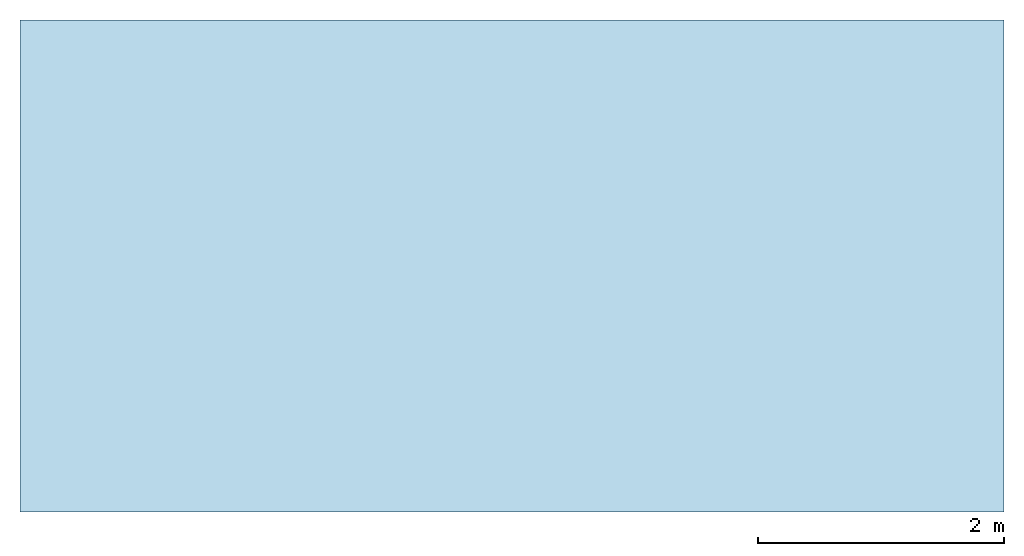
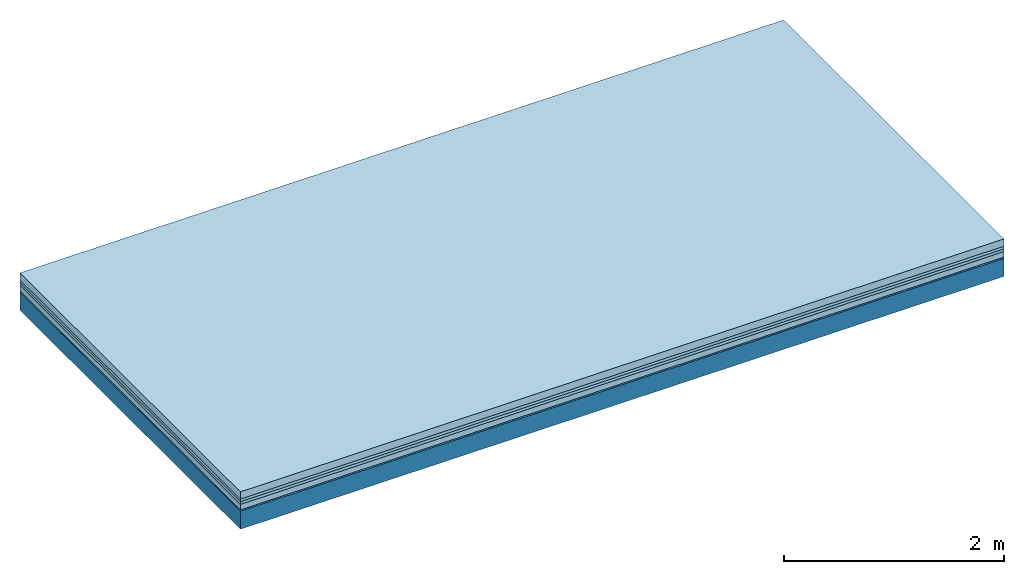
# One storey: 5 plates, 1 member, 1 element without a shape of its own.
"""IFC4 building model written with IfcOpenShell, lengths in metres."""

from ifc_helpers import new_model, si_unit, derived_unit, direction, frame, frame_2d, origin, origin_with_axes, place, context, project, spatial, rectangle, extrude, material, layer, layer_set, type_object, element, aggregate, save


model = new_model("IFC4")

# Units and contexts
plan_context = context("Plan", 3, precision=1e-05, world=origin(), true_north=direction((0.0, 1.0)))
model_context = context("Model", 3, precision=1e-05, world=origin(), true_north=direction((0.0, 1.0)))
ifc_project = project(units=[si_unit("LENGTHUNIT", "METRE"), derived_unit("SOUNDPRESSUREUNIT", [(si_unit("PRESSUREUNIT", "PASCAL", prefix="MICRO"), 0)]), si_unit("ENERGYUNIT", "JOULE", prefix="MEGA"), si_unit("MASSUNIT", "GRAM", prefix="KILO"), derived_unit("THERMALTRANSMITTANCEUNIT", [(si_unit("POWERUNIT", "WATT"), 1), (si_unit("AREAUNIT", "SQUARE_METRE"), -1), (si_unit("THERMODYNAMICTEMPERATUREUNIT", "KELVIN"), -1)]), derived_unit("AREADENSITYUNIT", [(si_unit("MASSUNIT", "GRAM", prefix="KILO"), 1), (si_unit("AREAUNIT", "SQUARE_METRE"), -1)]), derived_unit("USERDEFINED", [(si_unit("ENERGYUNIT", "JOULE", prefix="MEGA"), 1), (si_unit("AREAUNIT", "SQUARE_METRE"), -1)])], contexts=[plan_context, model_context])

# Site, building, storey
site = spatial("IfcSite", under=ifc_project)
building_placement = place(None, origin())
building = spatial("IfcBuilding", under=site, at=building_placement)
storey_placement = place(building_placement, origin())
storey = spatial("IfcBuildingStorey", under=building, at=storey_placement)

# Slab, member, plates
ifc_material_1 = material(Name="Cement screed", Category="04.006")
ifc_layer_1 = layer(ifc_material_1, 0.08, Name="On-material")
ifc_material_2 = material()
ifc_layer_2 = layer(ifc_material_2, 0.03, Name="Impact sound insulation")
ifc_material_3 = material()
ifc_layer_3 = layer(ifc_material_3, 0.03, Name="Additional insulation")
ifc_material_4 = material(Category="03.011")
ifc_layer_4 = layer(ifc_material_4, 0.06, Name="on Supporting structure")
ifc_material_5 = material(Category="03.007")
ifc_layer_5 = layer(ifc_material_5, 0.015, Name="Sub-floor")
ifc_material_6 = material(Name="of the art")
ifc_layer_6 = layer(ifc_material_6, 0.0, Name="Bond")
ifc_layer_7 = layer(None, 0.2, Name="Supporting structure")
ifc_layer_set = layer_set([ifc_layer_1, ifc_layer_2, ifc_layer_3, ifc_layer_4, ifc_layer_5, ifc_layer_6, ifc_layer_7])
slab_type = type_object("IfcSlabType", Name="A1092", PredefinedType="NOTDEFINED", material=ifc_layer_set)
slab_placement = place(None, frame((0.0, 0.0, 0.0), z_axis=(0.0, 0.0, -1.0), x_axis=(1.0, 0.0, 0.0)))
slab = element("IfcSlab", 1, at=slab_placement, inside=storey, type_object=slab_type, material=ifc_layer_set, Name="Slab #1")
ifc_material_7 = material()
member_placement = place(slab_placement, origin())
member = element("IfcMember", 2, at=member_placement, material=ifc_material_7, Name="Supporting structure", context=plan_context, shape_type="SweptSolid", body=[
    extrude(rectangle(XDim=1.0, YDim=0.2, at=frame_2d((0.5, 0.1), x_axis=(1.0, 0.0))), frame((0.0, 4.0, 0.215), z_axis=(0.0, -1.0, 0.0), x_axis=(1.0, 0.0, 0.0)), (0.0, 0.0, 1.0), 4.0),
    extrude(rectangle(XDim=1.0, YDim=0.2, at=frame_2d((0.5, 0.1), x_axis=(1.0, 0.0))), frame((1.0, 4.0, 0.215), z_axis=(0.0, -1.0, 0.0), x_axis=(1.0, 0.0, 0.0)), (0.0, 0.0, 1.0), 4.0),
    extrude(rectangle(XDim=1.0, YDim=0.2, at=frame_2d((0.5, 0.1), x_axis=(1.0, 0.0))), frame((2.0, 4.0, 0.215), z_axis=(0.0, -1.0, 0.0), x_axis=(1.0, 0.0, 0.0)), (0.0, 0.0, 1.0), 4.0),
    extrude(rectangle(XDim=1.0, YDim=0.2, at=frame_2d((0.5, 0.1), x_axis=(1.0, 0.0))), frame((3.0, 4.0, 0.215), z_axis=(0.0, -1.0, 0.0), x_axis=(1.0, 0.0, 0.0)), (0.0, 0.0, 1.0), 4.0),
    extrude(rectangle(XDim=1.0, YDim=0.2, at=frame_2d((0.5, 0.1), x_axis=(1.0, 0.0))), frame((4.0, 4.0, 0.215), z_axis=(0.0, -1.0, 0.0), x_axis=(1.0, 0.0, 0.0)), (0.0, 0.0, 1.0), 4.0),
    extrude(rectangle(XDim=1.0, YDim=0.2, at=frame_2d((0.5, 0.1), x_axis=(1.0, 0.0))), frame((5.0, 4.0, 0.215), z_axis=(0.0, -1.0, 0.0), x_axis=(1.0, 0.0, 0.0)), (0.0, 0.0, 1.0), 4.0),
    extrude(rectangle(XDim=1.0, YDim=0.2, at=frame_2d((0.5, 0.1), x_axis=(1.0, 0.0))), frame((6.0, 4.0, 0.215), z_axis=(0.0, -1.0, 0.0), x_axis=(1.0, 0.0, 0.0)), (0.0, 0.0, 1.0), 4.0),
    extrude(rectangle(XDim=1.0, YDim=0.2, at=frame_2d((0.5, 0.1), x_axis=(1.0, 0.0))), frame((7.0, 4.0, 0.215), z_axis=(0.0, -1.0, 0.0), x_axis=(1.0, 0.0, 0.0)), (0.0, 0.0, 1.0), 4.0),
])
plate_1_placement = place(slab_placement, origin())
plate_1 = element("IfcPlate", 3, at=plate_1_placement, material=ifc_material_1, Name="On-material", context=plan_context, shape_type="SweptSolid", body=[
    extrude(rectangle(XDim=8.0, YDim=4.0, at=frame_2d((4.0, 2.0), x_axis=(1.0, 0.0))), origin_with_axes(), (0.0, 0.0, 1.0), 0.08),
])
plate_2_placement = place(slab_placement, origin())
plate_2 = element("IfcPlate", 4, at=plate_2_placement, material=ifc_material_2, Name="Impact sound insulation", context=plan_context, shape_type="SweptSolid", body=[
    extrude(rectangle(XDim=8.0, YDim=4.0, at=frame_2d((4.0, 2.0), x_axis=(1.0, 0.0))), frame((0.0, 0.0, 0.08), z_axis=(0.0, 0.0, 1.0), x_axis=(1.0, 0.0, 0.0)), (0.0, 0.0, 1.0), 0.03),
])
plate_3_placement = place(slab_placement, origin())
plate_3 = element("IfcPlate", 5, at=plate_3_placement, material=ifc_material_3, Name="Additional insulation", context=plan_context, shape_type="SweptSolid", body=[
    extrude(rectangle(XDim=8.0, YDim=4.0, at=frame_2d((4.0, 2.0), x_axis=(1.0, 0.0))), frame((0.0, 0.0, 0.11), z_axis=(0.0, 0.0, 1.0), x_axis=(1.0, 0.0, 0.0)), (0.0, 0.0, 1.0), 0.03),
])
plate_4_placement = place(slab_placement, origin())
plate_4 = element("IfcPlate", 6, at=plate_4_placement, material=ifc_material_4, Name="on Supporting structure", context=plan_context, shape_type="SweptSolid", body=[
    extrude(rectangle(XDim=8.0, YDim=4.0, at=frame_2d((4.0, 2.0), x_axis=(1.0, 0.0))), frame((0.0, 0.0, 0.14), z_axis=(0.0, 0.0, 1.0), x_axis=(1.0, 0.0, 0.0)), (0.0, 0.0, 1.0), 0.06),
])
plate_5_placement = place(slab_placement, origin())
plate_5 = element("IfcPlate", 7, at=plate_5_placement, material=ifc_material_5, Name="Sub-floor", context=plan_context, shape_type="SweptSolid", body=[
    extrude(rectangle(XDim=8.0, YDim=4.0, at=frame_2d((4.0, 2.0), x_axis=(1.0, 0.0))), frame((0.0, 0.0, 0.2), z_axis=(0.0, 0.0, 1.0), x_axis=(1.0, 0.0, 0.0)), (0.0, 0.0, 1.0), 0.015),
])
aggregate(slab, [plate_1, plate_2, plate_3, plate_4, plate_5, member])

save(model, "model.ifc")
